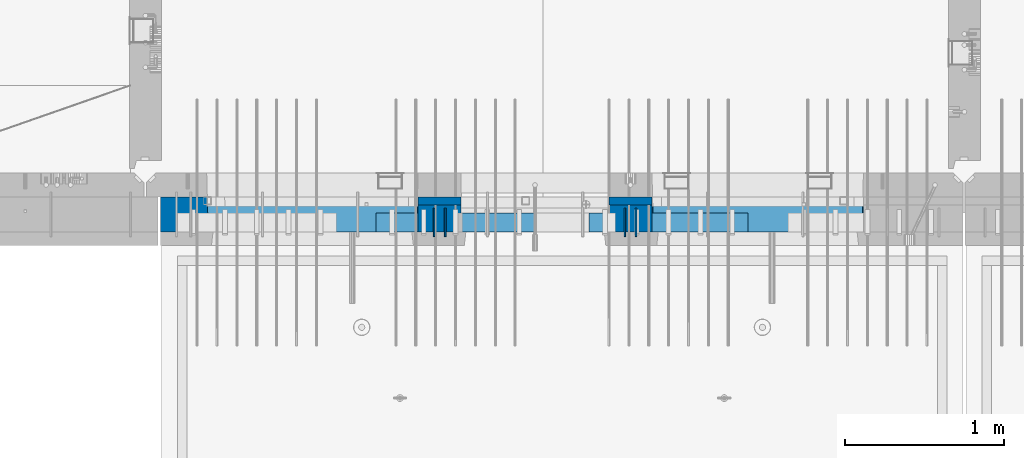
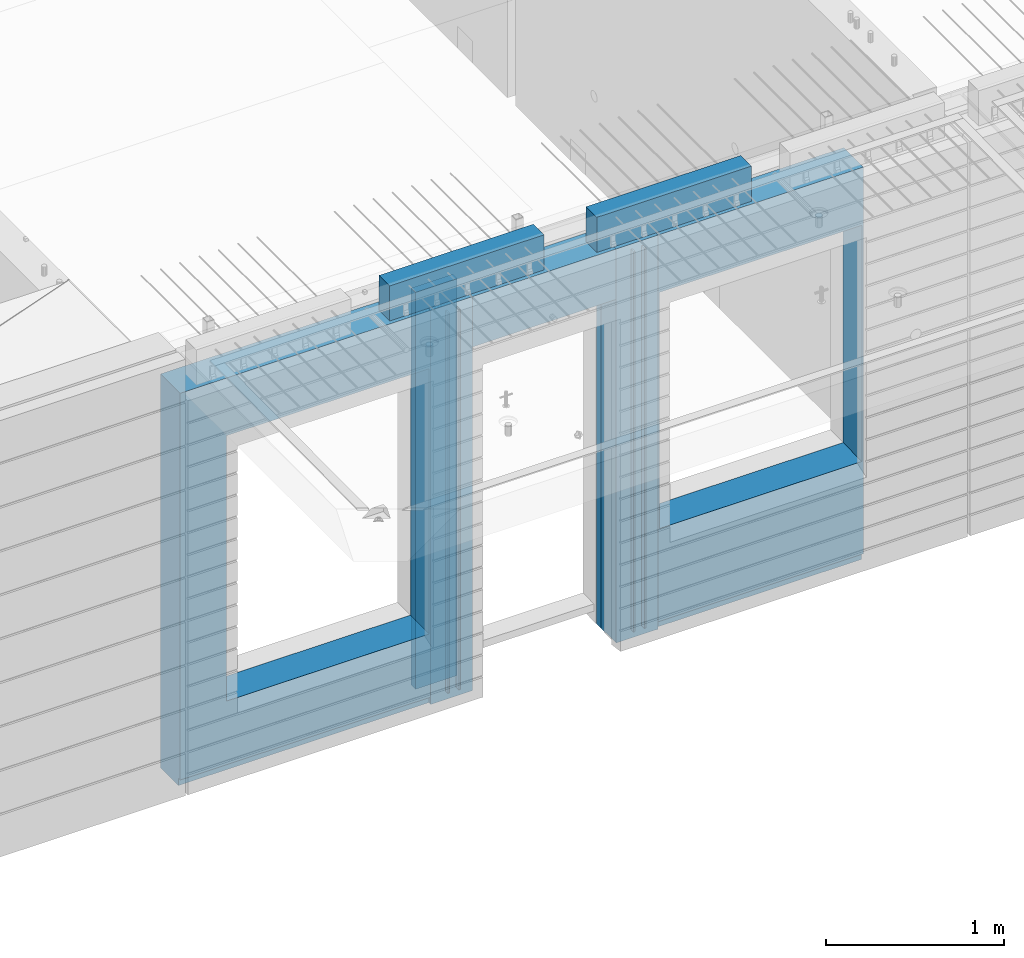
# One storey, part 221 of 341: 11 walls, 4 elements without a shape of their own.
"""IFC2X3 building model written with IfcOpenShell, lengths in millimetres."""

from ifc_helpers import new_model, si_unit, frame, origin_with_axes, place, context, subcontext, project, spatial, faceted_brep, material, type_object, element, aggregate, save


model = new_model("IFC2X3")

# Units and contexts
model_context = context("Model", 3, precision=1e-05, world=origin_with_axes())
body_context = subcontext(model_context, "Body", "Model", "MODEL_VIEW")
ifc_project = project(units=[si_unit("LENGTHUNIT", "METRE", prefix="MILLI"), si_unit("AREAUNIT", "SQUARE_METRE"), si_unit("VOLUMEUNIT", "CUBIC_METRE"), si_unit("MASSUNIT", "GRAM", prefix="KILO"), si_unit("TIMEUNIT", "SECOND"), si_unit("PLANEANGLEUNIT", "RADIAN"), si_unit("SOLIDANGLEUNIT", "STERADIAN"), si_unit("THERMODYNAMICTEMPERATUREUNIT", "DEGREE_CELSIUS"), si_unit("LUMINOUSINTENSITYUNIT", "LUMEN")], contexts=[model_context])

# Site, building, storey
site_placement = place(None, origin_with_axes())
site = spatial("IfcSite", under=ifc_project, at=site_placement, CompositionType="ELEMENT")
building_placement = place(site_placement, origin_with_axes())
building = spatial("IfcBuilding", under=site, at=building_placement, CompositionType="ELEMENT")
storey_placement = place(building_placement, origin_with_axes())
storey = spatial("IfcBuildingStorey", under=building, at=storey_placement, Name="5", CompositionType="ELEMENT", Elevation=0.0)

# Assembly, walls
assembly_1_placement = place(storey_placement, origin_with_axes())
assembly_1 = element("IfcElementAssembly", 1, at=assembly_1_placement, inside=storey, AssemblyPlace="NOTDEFINED", PredefinedType="REINFORCEMENT_UNIT")
ifc_material_1 = material(Name="Undefined")
wall_type_1 = type_object("IfcWallType", PredefinedType="NOTDEFINED")
wall_1_placement = place(assembly_1_placement, frame((18475.0, 7780.0, 95115.0), z_axis=(0.0, 0.0, 1.0), x_axis=(0.0, -1.0, 0.0)))
wall_1 = element("IfcWall", 2, at=wall_1_placement, type_object=wall_type_1, material=ifc_material_1, Name="(PD)", context=body_context, shape_type="Brep", body=[
    faceted_brep([(0.0, 5.0, -1300.0), (0.0, 5.0, 1300.0), (180.0, 5.0, 1300.0), (180.0, 5.0, -1300.0), (0.0, -5.0, 1300.0), (180.0, -5.0, 1300.0), (0.0, -5.0, -1300.0), (180.0, -5.0, -1300.0)], [[[0, 1, 2, 3]], [[1, 4, 5, 2]], [[4, 6, 7, 5]], [[6, 0, 3, 7]], [[5, 7, 3, 2]], [[6, 4, 1, 0]]]),
])
wall_2_placement = place(assembly_1_placement, frame((18545.0, 7780.0, 95115.0), z_axis=(0.0, 0.0, 1.0), x_axis=(0.0, -1.0, 0.0)))
wall_2 = element("IfcWall", 3, at=wall_2_placement, type_object=wall_type_1, material=ifc_material_1, Name="(PD)", context=body_context, shape_type="Brep", body=[
    faceted_brep([(0.0, 5.0, -1300.0), (0.0, 5.0, 1300.0), (180.0, 5.0, 1300.0), (180.0, 5.0, -1300.0), (0.0, -5.0, 1300.0), (180.0, -5.0, 1300.0), (0.0, -5.0, -1300.0), (180.0, -5.0, -1300.0)], [[[0, 1, 2, 3]], [[1, 4, 5, 2]], [[4, 6, 7, 5]], [[6, 0, 3, 7]], [[5, 7, 3, 2]], [[6, 4, 1, 0]]]),
])
wall_3_placement = place(assembly_1_placement, frame((19675.0, 7779.99999999997, 95115.0), z_axis=(0.0, 0.0, 1.0), x_axis=(0.0, -1.0, 0.0)))
wall_3 = element("IfcWall", 4, at=wall_3_placement, type_object=wall_type_1, material=ifc_material_1, Name="(PD)", context=body_context, shape_type="Brep", body=[
    faceted_brep([(0.0, 5.0, -1300.0), (0.0, 5.0, 1300.0), (180.0, 5.0, 1300.0), (180.0, 5.0, -1300.0), (0.0, -5.0, 1300.0), (180.0, -5.0, 1300.0), (0.0, -5.0, -1300.0), (180.0, -5.0, -1300.0)], [[[0, 1, 2, 3]], [[1, 4, 5, 2]], [[4, 6, 7, 5]], [[6, 0, 3, 7]], [[5, 7, 3, 2]], [[6, 4, 1, 0]]]),
])
wall_4_placement = place(assembly_1_placement, frame((19745.0, 7780.0, 95115.0), z_axis=(0.0, 0.0, 1.0), x_axis=(0.0, -1.0, 0.0)))
wall_4 = element("IfcWall", 5, at=wall_4_placement, type_object=wall_type_1, material=ifc_material_1, Name="(PD)", context=body_context, shape_type="Brep", body=[
    faceted_brep([(0.0, 5.0, -1300.0), (0.0, 5.0, 1300.0), (180.0, 5.0, 1300.0), (180.0, 5.0, -1300.0), (0.0, -5.0, 1300.0), (180.0, -5.0, 1300.0), (0.0, -5.0, -1300.0), (180.0, -5.0, -1300.0)], [[[0, 1, 2, 3]], [[1, 4, 5, 2]], [[4, 6, 7, 5]], [[6, 0, 3, 7]], [[5, 7, 3, 2]], [[6, 4, 1, 0]]]),
])

# Assemblies, walls
assembly_2_placement = place(storey_placement, origin_with_axes())
assembly_2 = element("IfcElementAssembly", 6, at=assembly_2_placement, inside=storey, AssemblyPlace="NOTDEFINED", PredefinedType="REINFORCEMENT_UNIT")
assembly_3_placement = place(assembly_2_placement, origin_with_axes())
assembly_3 = element("IfcElementAssembly", 7, at=assembly_3_placement, Name="Steel Assembly", AssemblyPlace="NOTDEFINED", PredefinedType="NOTDEFINED")
ifc_material_2 = material()
wall_type_2 = type_object("IfcWallType", PredefinedType="NOTDEFINED")
wall_5_placement = place(assembly_3_placement, frame((18109.9998568133, 7690.00021946163, 96590.0), z_axis=(0.0, 0.0, 1.0), x_axis=(1.0, 0.0, 0.0)))
wall_5 = element("IfcWall", 8, at=wall_5_placement, type_object=wall_type_2, material=ifc_material_2, context=body_context, shape_type="Brep", body=[
    faceted_brep([(0.0, 60.0, -120.0), (0.0, 60.0, 120.0), (1000.0, 60.0, 120.0), (1000.0, 60.0, -120.0), (0.0, -60.0, 120.0), (1000.0, -60.0, 120.0), (0.0, -60.0, -120.0), (1000.0, -60.0, -120.0)], [[[0, 1, 2, 3]], [[1, 4, 5, 2]], [[4, 6, 7, 5]], [[6, 0, 3, 7]], [[5, 7, 3, 2]], [[6, 4, 1, 0]]]),
])
aggregate(assembly_3, [wall_5])
assembly_4_placement = place(assembly_2_placement, origin_with_axes())
assembly_4 = element("IfcElementAssembly", 9, at=assembly_4_placement, Name="Steel Assembly", AssemblyPlace="NOTDEFINED", PredefinedType="NOTDEFINED")
aggregate(assembly_2, [assembly_4, assembly_3])
wall_6_placement = place(assembly_4_placement, frame((19449.9998568133, 7690.00021946163, 96590.0), z_axis=(0.0, 0.0, 1.0), x_axis=(1.0, 0.0, 0.0)))
wall_6 = element("IfcWall", 10, at=wall_6_placement, type_object=wall_type_2, material=ifc_material_2, context=body_context, shape_type="Brep", body=[
    faceted_brep([(0.0, 60.0, -120.0), (0.0, 60.0, 120.0), (1000.0, 60.0, 120.0), (1000.0, 60.0, -120.0), (0.0, -60.0, 120.0), (1000.0, -60.0, 120.0), (0.0, -60.0, -120.0), (1000.0, -60.0, -120.0)], [[[0, 1, 2, 3]], [[1, 4, 5, 2]], [[4, 6, 7, 5]], [[6, 0, 3, 7]], [[5, 7, 3, 2]], [[6, 4, 1, 0]]]),
])
aggregate(assembly_4, [wall_6])

# Wall
ifc_material_3 = material(Name="CONCRETE/C35/45")
wall_type_3 = type_object("IfcWallType", PredefinedType="NOTDEFINED")
wall_7_placement = place(assembly_1_placement, frame((18645.0200381475, 7825.0, 95112.5), z_axis=(0.0, 0.0, 1.0), x_axis=(-1.0, 3.00000001838171e-08, 0.0)))
wall_7 = element("IfcWall", 11, at=wall_7_placement, type_object=wall_type_3, material=ifc_material_3, context=body_context, shape_type="Brep", body=[
    faceted_brep([(0.0, 25.0, -1357.5), (0.0, 25.0, 1357.5), (270.001908754726, 25.0, 1357.5), (270.001908754726, 25.0, -1357.5), (0.0, -25.0, 1357.5), (270.001908754726, -25.0, 1357.5), (0.0, -25.0, -1357.5), (270.001908754726, -25.0, -1357.5)], [[[0, 1, 2, 3]], [[1, 4, 5, 2]], [[4, 6, 7, 5]], [[6, 0, 3, 7]], [[5, 7, 3, 2]], [[6, 4, 1, 0]]]),
])

wall_8_placement = place(assembly_1_placement, frame((19845.0100381475, 7825.0, 95112.5), z_axis=(0.0, 0.0, 1.0), x_axis=(-1.0, 3.00000001838171e-08, 0.0)))
wall_8 = element("IfcWall", 12, at=wall_8_placement, type_object=wall_type_3, material=ifc_material_3, context=body_context, shape_type="Brep", body=[
    faceted_brep([(0.0, 25.0, -1357.5), (0.0, 25.0, 1357.5), (270.001908754726, 25.0, 1357.5), (270.001908754726, 25.0, -1357.5), (0.0, -25.0, 1357.5), (270.001908754726, -25.0, 1357.5), (0.0, -25.0, -1357.5), (270.001908754726, -25.0, -1357.5)], [[[0, 1, 2, 3]], [[1, 4, 5, 2]], [[4, 6, 7, 5]], [[6, 0, 3, 7]], [[5, 7, 3, 2]], [[6, 4, 1, 0]]]),
])

ifc_material_4 = material(Name="SPU")
wall_type_4 = type_object("IfcWallType", PredefinedType="NOTDEFINED")
wall_9_placement = place(assembly_1_placement, frame((18645.0100381475, 7715.0, 95102.5), z_axis=(0.0, 0.0, 1.0), x_axis=(-1.0, 3.00000001838171e-08, 0.0)))
wall_9 = element("IfcWall", 13, at=wall_9_placement, type_object=wall_type_4, material=ifc_material_4, context=body_context, shape_type="Brep", body=[
    faceted_brep([(0.0, 85.0, -1347.5), (0.0, 85.0, 1347.5), (270.001908754726, 85.0, 1347.5), (270.001908754726, 85.0, -1347.5), (0.0, -85.0, 1347.5), (270.001908754726, -85.0, 1347.5), (0.0, -85.0, -1347.5), (270.001908754726, -85.0, -1347.5)], [[[0, 1, 2, 3]], [[1, 4, 5, 2]], [[4, 6, 7, 5]], [[6, 0, 3, 7]], [[5, 7, 3, 2]], [[6, 4, 1, 0]]]),
])

wall_10_placement = place(assembly_1_placement, frame((19845.0100381475, 7715.0, 95102.5), z_axis=(0.0, 0.0, 1.0), x_axis=(-1.0, 3.00000001838171e-08, 0.0)))
wall_10 = element("IfcWall", 14, at=wall_10_placement, type_object=wall_type_4, material=ifc_material_4, context=body_context, shape_type="Brep", body=[
    faceted_brep([(0.0, 85.0, -1347.5), (0.0, 85.0, 1347.5), (270.001908754726, 85.0, 1347.5), (270.001908754726, 85.0, -1347.5), (0.0, -85.0, 1347.5), (270.001908754726, -85.0, 1347.5), (0.0, -85.0, -1347.5), (270.001908754726, -85.0, -1347.5)], [[[0, 1, 2, 3]], [[1, 4, 5, 2]], [[4, 6, 7, 5]], [[6, 0, 3, 7]], [[5, 7, 3, 2]], [[6, 4, 1, 0]]]),
])

ifc_material_5 = material(Name="COS5gt")
wall_type_5 = type_object("IfcWallType", PredefinedType="NOTDEFINED")
wall_11_placement = place(assembly_1_placement, frame((21175.0, 7740.0, 95102.5), z_axis=(0.0, 0.0, 1.0), x_axis=(-1.0, 3.00000001838171e-08, 0.0)))
wall_11 = element("IfcWall", 15, at=wall_11_placement, type_object=wall_type_5, material=ifc_material_5, context=body_context, shape_type="Brep", body=[
    faceted_brep([(4420.0, -110.0, 1347.5), (4420.0, 110.0, 1347.5), (2799.99187060721, 110.0, 1347.5), (2799.99187060721, -10.0, 1347.5), (2799.9818706072, -110.0, 1347.5), (4420.0, 110.0, -1297.5), (4420.0, 90.0, -1297.5), (2799.99187060721, 90.0, -1297.5), (2799.99187060721, 110.0, -1297.5), (4420.0, -110.0, -1347.5), (4420.0, 90.0, -1347.5), (2799.99187060721, 90.0, -1347.5), (2799.99187060721, -10.0, -1347.5), (2809.99937278789, 110.0, -862.5), (2839.99937278789, 110.0, -862.5), (4089.99937278789, 110.0, -862.5), (4119.99937278789, 110.0, -862.5), (4119.99937278789, 110.0, -857.5), (4119.99937278789, 110.0, 952.5), (2809.99937278789, 110.0, 952.5), (2809.99937278789, 110.0, -857.5), (2804.05342684194, -110.0, -868.445945945947), (2804.05342684194, -109.999999999999, 958.445945945947), (4125.94531873383, -110.0, -868.445945945947), (4125.94531873383, -109.999999999999, 958.445945945947), (2799.9818706072, -110.0, -1347.5), (1329.98996185248, -110.0, 1347.5), (1329.98996185248, -110.0, -1347.5), (1329.98996185248, -10.0, -1347.5), (1329.98996185248, -10.0, 1347.5), (0.0, -110.0, -1347.5), (0.0, 90.0, -1347.5), (1329.98996185248, 90.0, -1347.5), (0.0, 90.0, -1297.5), (0.0, 110.0, -1297.5), (1329.98996185248, 110.0, -1297.5), (1329.98996185248, 90.0, -1297.5), (0.0, -110.0, 1347.5), (0.0, 110.0, 1347.5), (1329.98996185248, 110.0, 1347.5), (10.0001357273395, 110.0, -662.5), (40.0001357273395, 110.0, -662.5), (1290.00013572734, 110.0, -662.5), (1320.00013572734, 110.0, -662.5), (1320.00013572734, 110.0, -657.5), (1320.00013572734, 110.0, 952.5), (10.0001357273395, 110.0, 952.5), (10.0001357273395, 110.0, -657.5), (4.05418978139278, -110.0, -668.445945945947), (4.05418978139278, -109.999999999999, 958.445945945947), (1325.94608167329, -110.0, -668.445945945947), (1325.94608167329, -109.999999999999, 958.445945945947), (1600.00051719707, -109.999999999999, 1002.5), (1599.99187060721, -110.0, 1347.5), (1599.99187060721, -10.0, 1347.5), (1600.00051719707, -10.0, 1002.5), (1600.00051719707, 110.0, 1002.5), (1599.99187060721, 110.0, 1347.5), (2529.98996185248, 110.0, 1347.5), (2529.98996185248, 110.0, 1002.5), (2529.98996185248, -10.0, 1347.5), (2529.98996185248, -10.0, 1002.5), (2529.97996185248, -110.0, 1347.5), (2529.97996185248, -109.999999999999, 1002.5)], [[[0, 1, 2, 3, 4]], [[5, 6, 7, 8]], [[1, 0, 9, 10, 6, 5]], [[6, 10, 11, 7]], [[2, 8, 7, 11, 12, 3]], [[1, 5, 8, 2], [13, 14, 15, 16, 17, 18, 19, 20]], [[21, 13, 20, 19, 22]], [[23, 16, 15, 14, 13, 21]], [[17, 16, 23, 24, 18]], [[22, 19, 18, 24]], [[9, 0, 4, 25], [23, 21, 22, 24]], [[11, 10, 9, 25, 12]], [[4, 3, 12, 25]], [[26, 27, 28, 29]], [[27, 30, 31, 32, 28]], [[33, 34, 35, 36]], [[31, 33, 36, 32]], [[30, 37, 38, 34, 33, 31]], [[38, 37, 26, 29, 39]], [[29, 28, 32, 36, 35, 39]], [[34, 38, 39, 35], [40, 41, 42, 43, 44, 45, 46, 47]], [[48, 40, 47, 46, 49]], [[50, 43, 42, 41, 40, 48]], [[44, 43, 50, 51, 45]], [[49, 46, 45, 51]], [[37, 30, 27, 26], [50, 48, 49, 51]], [[52, 53, 54, 55]], [[56, 57, 58, 59]], [[59, 58, 60, 61]], [[62, 63, 61, 60]], [[53, 52, 63, 62]], [[56, 59, 61, 63, 52, 55]], [[54, 57, 56, 55]], [[62, 60, 58, 57, 54, 53]]]),
])

aggregate(assembly_1, [wall_7, wall_9, wall_10, wall_1, wall_2, wall_8, wall_3, wall_4, wall_11])

save(model, "model.ifc")
